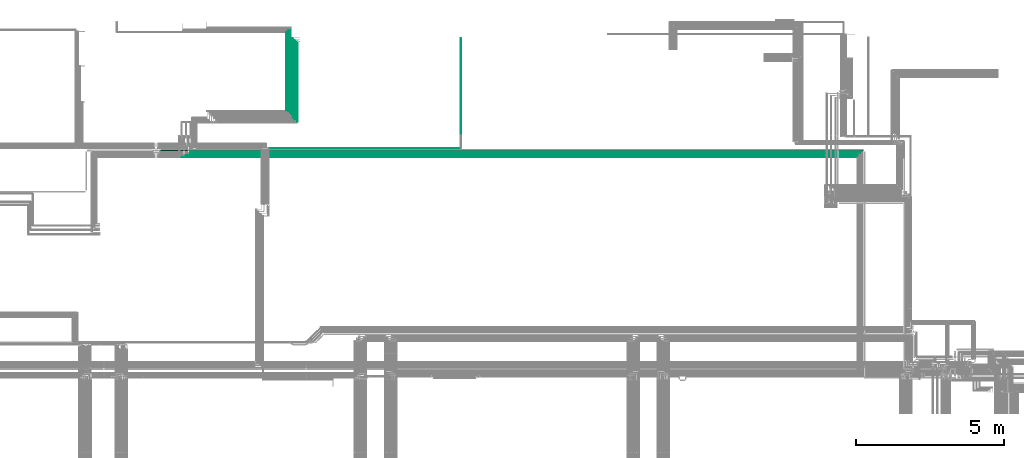
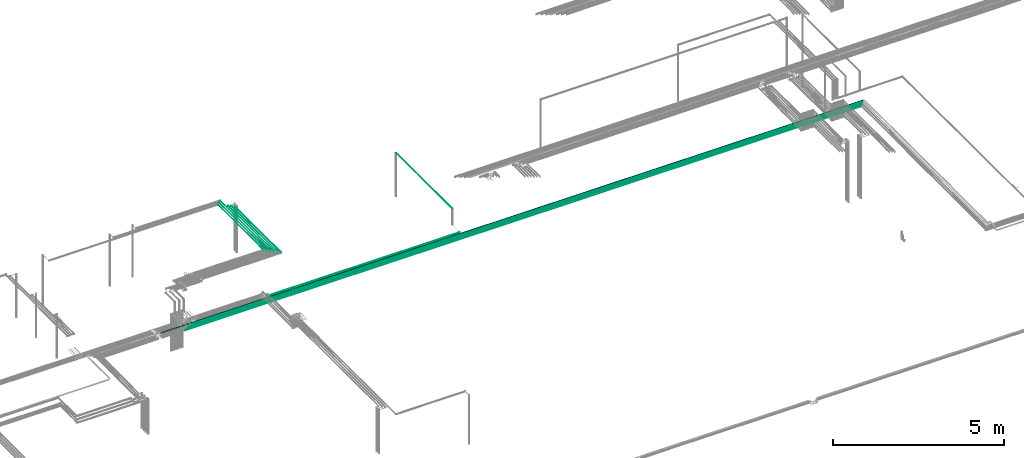
# One storey, part 104 of 331: 12 flow segments.
"""IFC2X3 building model written with IfcOpenShell, lengths in millimetres."""

from ifc_helpers import new_model, entity, si_unit, converted_unit, derived_unit, direction, frame, frame_2d, origin, origin_2d_with_axis, place, context, subcontext, project, spatial, circle, extrude, type_object, element, save


model = new_model("IFC2X3")

# Units and contexts
model_context = context("Model", 3, precision=0.01, world=origin(), true_north=direction((6.12303176911189e-17, 1.0)))
body_context = subcontext(model_context, "Body", "Model", "MODEL_VIEW")
ifc_project = project(units=[si_unit("LENGTHUNIT", "METRE", prefix="MILLI"), si_unit("AREAUNIT", "SQUARE_METRE"), si_unit("VOLUMEUNIT", "CUBIC_METRE"), converted_unit("PLANEANGLEUNIT", "DEGREE", entity("IfcRatioMeasure", 0.0174532925199433), si_unit("PLANEANGLEUNIT", "RADIAN"), dimensions=[0, 0, 0, 0, 0, 0, 0]), si_unit("MASSUNIT", "GRAM", prefix="KILO"), derived_unit("MASSDENSITYUNIT", [(si_unit("MASSUNIT", "GRAM", prefix="KILO"), 1), (si_unit("LENGTHUNIT", "METRE"), -3)]), derived_unit("MOMENTOFINERTIAUNIT", [(si_unit("LENGTHUNIT", "METRE"), 4)]), si_unit("TIMEUNIT", "SECOND"), si_unit("FREQUENCYUNIT", "HERTZ"), si_unit("THERMODYNAMICTEMPERATUREUNIT", "DEGREE_CELSIUS"), derived_unit("THERMALTRANSMITTANCEUNIT", [(si_unit("MASSUNIT", "GRAM", prefix="KILO"), 1), (si_unit("THERMODYNAMICTEMPERATUREUNIT", "KELVIN"), -1), (si_unit("TIMEUNIT", "SECOND"), -3)]), derived_unit("VOLUMETRICFLOWRATEUNIT", [(si_unit("LENGTHUNIT", "METRE"), 3), (si_unit("TIMEUNIT", "SECOND"), -1)]), derived_unit("MASSFLOWRATEUNIT", [(si_unit("MASSUNIT", "GRAM", prefix="KILO"), 1), (si_unit("TIMEUNIT", "SECOND"), -1)]), derived_unit("ROTATIONALFREQUENCYUNIT", [(si_unit("TIMEUNIT", "SECOND"), -1)]), si_unit("ELECTRICCURRENTUNIT", "AMPERE"), si_unit("ELECTRICVOLTAGEUNIT", "VOLT"), si_unit("POWERUNIT", "WATT"), si_unit("FORCEUNIT", "NEWTON", prefix="KILO"), si_unit("ILLUMINANCEUNIT", "LUX"), si_unit("LUMINOUSFLUXUNIT", "LUMEN"), si_unit("LUMINOUSINTENSITYUNIT", "CANDELA"), derived_unit("USERDEFINED", [(si_unit("MASSUNIT", "GRAM", prefix="KILO"), -1), (si_unit("LENGTHUNIT", "METRE"), -2), (si_unit("TIMEUNIT", "SECOND"), 3), (si_unit("LUMINOUSFLUXUNIT", "LUMEN"), 1)]), derived_unit("LINEARVELOCITYUNIT", [(si_unit("LENGTHUNIT", "METRE"), 1), (si_unit("TIMEUNIT", "SECOND"), -1)]), si_unit("PRESSUREUNIT", "PASCAL"), derived_unit("USERDEFINED", [(si_unit("LENGTHUNIT", "METRE"), -2), (si_unit("MASSUNIT", "GRAM", prefix="KILO"), 1), (si_unit("TIMEUNIT", "SECOND"), -2)]), derived_unit("LINEARFORCEUNIT", [(si_unit("MASSUNIT", "GRAM", prefix="KILO"), 1), (si_unit("LENGTHUNIT", "METRE"), 1), (si_unit("TIMEUNIT", "SECOND"), -2), (si_unit("LENGTHUNIT", "METRE"), -1)]), derived_unit("PLANARFORCEUNIT", [(si_unit("MASSUNIT", "GRAM", prefix="KILO"), 1), (si_unit("LENGTHUNIT", "METRE"), 1), (si_unit("TIMEUNIT", "SECOND"), -2), (si_unit("LENGTHUNIT", "METRE"), -2)])], contexts=[model_context])

# Site, building, storey
site_placement = place(None, frame((0.0, -0.00077364408347762, 0.0)))
site = spatial("IfcSite", under=ifc_project, at=site_placement, CompositionType="ELEMENT")
building_placement = place(site_placement, origin())
building = spatial("IfcBuilding", under=site, at=building_placement, CompositionType="ELEMENT")
storey_placement = place(building_placement, origin())
storey = spatial("IfcBuildingStorey", under=building, at=storey_placement, CompositionType="ELEMENT", Elevation=0.0)

# Flow segments
pipe_segment_type = type_object("IfcPipeSegmentType", PredefinedType="NOTDEFINED")
flow_segment_1_placement = place(building_placement, frame((37859.2598936966, 15737.3893979669, 6662.40472776406)))
element("IfcFlowSegment", 1, at=flow_segment_1_placement, inside=storey, type_object=pipe_segment_type, context=body_context, shape_type="SweptSolid", body=[
    extrude(circle(Radius=11.0, at=frame_2d((-5.63090907235164e-11, 0.0), x_axis=(1.0, 0.0))), frame((0.0, 12.595272235974, 12.5952722359156), z_axis=(1.0, 0.0, 0.0), x_axis=(0.0, 1.0, 0.0)), (0.0, 0.0, 1.0), 22706.73687144),
])
flow_segment_2_placement = place(building_placement, frame((37704.2598936966, 15667.389397967, 6667.40472776406)))
element("IfcFlowSegment", 2, at=flow_segment_2_placement, inside=storey, type_object=pipe_segment_type, context=body_context, shape_type="SweptSolid", body=[
    extrude(circle(Radius=6.0, at=frame_2d((-6.49720277579036e-12, 1.08286712929839e-12), x_axis=(1.0, 0.0))), frame((0.0, 7.5952722359232, 7.59527223591454), z_axis=(1.0, 0.0, 0.0), x_axis=(0.0, 1.0, 0.0)), (0.0, 0.0, 1.0), 22796.73687144),
])
flow_segment_3_placement = place(building_placement, frame((37554.2598936966, 15592.389397967, 6667.40472776405)))
element("IfcFlowSegment", 3, at=flow_segment_3_placement, inside=storey, type_object=pipe_segment_type, context=body_context, shape_type="SweptSolid", body=[
    extrude(circle(Radius=6.0, at=frame_2d((-5.41433564649196e-11, 1.08286712929839e-12), x_axis=(1.0, 0.0))), frame((0.0, 7.59527223597085, 7.59527223591454), z_axis=(1.0, 0.0, 0.0), x_axis=(0.0, 1.0, 0.0)), (0.0, 0.0, 1.0), 22871.73687144),
])
flow_segment_4_placement = place(storey_placement, frame((41512.4054235649, 16788.9846702028, 7342.40472776409)))
element("IfcFlowSegment", 4, at=flow_segment_4_placement, inside=storey, type_object=pipe_segment_type, context=body_context, shape_type="SweptSolid", body=[
    extrude(circle(Radius=6.0, at=origin_2d_with_axis()), frame((7.59527223593186, 0.0, 7.59527223591562), z_axis=(0.0, 1.0, 0.0), x_axis=(1.0, 0.0, 0.0)), (0.0, 0.0, 1.0), 2700.28792796121),
])
flow_segment_5_placement = place(storey_placement, frame((41289.4054235649, 17009.9846702028, 7344.40472776408)))
element("IfcFlowSegment", 5, at=flow_segment_5_placement, inside=storey, type_object=pipe_segment_type, context=body_context, shape_type="SweptSolid", body=[
    extrude(circle(Radius=4.0, at=origin_2d_with_axis()), frame((5.59527223591499, 0.0, 5.59527223591607), z_axis=(0.0, 1.0, 0.0), x_axis=(1.0, 0.0, 0.0)), (0.0, 0.0, 1.0), 2950.00000000017),
])
flow_segment_6_placement = place(storey_placement, frame((41214.4054235649, 17084.9846702028, 7344.40472776408)))
element("IfcFlowSegment", 6, at=flow_segment_6_placement, inside=storey, type_object=pipe_segment_type, context=body_context, shape_type="SweptSolid", body=[
    extrude(circle(Radius=4.0, at=origin_2d_with_axis()), frame((5.59527223591499, 0.0, 5.59527223591607), z_axis=(0.0, 1.0, 0.0), x_axis=(1.0, 0.0, 0.0)), (0.0, 0.0, 1.0), 2800.00000000019),
])
flow_segment_7_placement = place(storey_placement, frame((41139.4054235649, 17159.9846702028, 7344.40472776408)))
element("IfcFlowSegment", 7, at=flow_segment_7_placement, inside=storey, type_object=pipe_segment_type, context=body_context, shape_type="SweptSolid", body=[
    extrude(circle(Radius=4.0, at=frame_2d((0.0, -1.08286712929839e-12), x_axis=(1.0, 0.0))), frame((5.59527223591499, 0.0, 5.59527223591716), z_axis=(0.0, 1.0, 0.0), x_axis=(-1.0, 0.0, 0.0)), (0.0, 0.0, 1.0), 2650.00000000021),
])
flow_segment_8_placement = place(storey_placement, frame((47040.0665845049, 16334.9846702028, 7244.40472776412)))
element("IfcFlowSegment", 8, at=flow_segment_8_placement, inside=storey, type_object=pipe_segment_type, context=body_context, shape_type="SweptSolid", body=[
    extrude(circle(Radius=4.0, at=frame_2d((-8.66293703438714e-12, -1.08286712929839e-12), x_axis=(1.0, 0.0))), frame((5.59527223591499, 0.0, 5.59527223591716), z_axis=(0.0, 1.0, 0.0), x_axis=(-1.0, 0.0, 0.0)), (0.0, 0.0, 1.0), 3283.28710551243),
])
flow_segment_9_placement = place(storey_placement, frame((40552.0053734283, 15894.3893979669, 6669.40472776408)))
element("IfcFlowSegment", 9, at=flow_segment_9_placement, inside=storey, type_object=pipe_segment_type, context=body_context, shape_type="SweptSolid", body=[
    extrude(circle(Radius=4.0, at=origin_2d_with_axis()), frame((0.0, 5.59527223591499, 5.59527223591607), z_axis=(1.0, 0.0, 0.0), x_axis=(0.0, 1.0, 0.0)), (0.0, 0.0, 1.0), 6483.65648331253),
])
flow_segment_10_placement = place(storey_placement, frame((41439.4054235649, 16859.9846702028, 7344.40472776408)))
element("IfcFlowSegment", 10, at=flow_segment_10_placement, inside=storey, type_object=pipe_segment_type, context=body_context, shape_type="SweptSolid", body=[
    extrude(circle(Radius=4.0, at=frame_2d((0.0, -1.08286712929839e-12), x_axis=(1.0, 0.0))), frame((5.59527223591499, 0.0, 5.59527223591716), z_axis=(0.0, 1.0, 0.0), x_axis=(-1.0, 0.0, 0.0)), (0.0, 0.0, 1.0), 2693.28710551248),
])
flow_segment_11_placement = place(storey_placement, frame((41364.4054235649, 16934.9846702028, 7344.40472776408)))
element("IfcFlowSegment", 11, at=flow_segment_11_placement, inside=storey, type_object=pipe_segment_type, context=body_context, shape_type="SweptSolid", body=[
    extrude(circle(Radius=4.0, at=frame_2d((0.0, -1.08286712929839e-12), x_axis=(1.0, 0.0))), frame((5.59527223591499, 0.0, 5.59527223591716), z_axis=(0.0, 1.0, 0.0), x_axis=(-1.0, 0.0, 0.0)), (0.0, 0.0, 1.0), 2683.28710551249),
])
flow_segment_12_placement = place(building_placement, frame((36904.4094162434, 15805.889397967, 6655.90472776407)))
element("IfcFlowSegment", 12, at=flow_segment_12_placement, inside=storey, type_object=pipe_segment_type, context=body_context, shape_type="SweptSolid", body=[
    extrude(circle(Radius=17.5, at=frame_2d((-4.33146851719357e-12, 0.0), x_axis=(1.0, 0.0))), frame((0.0, 19.0952722359206, 19.0952722359163), z_axis=(1.0, 0.0, 0.0), x_axis=(0.0, 1.0, 0.0)), (0.0, 0.0, 1.0), 23720.5873488932),
])

save(model, "model.ifc")
